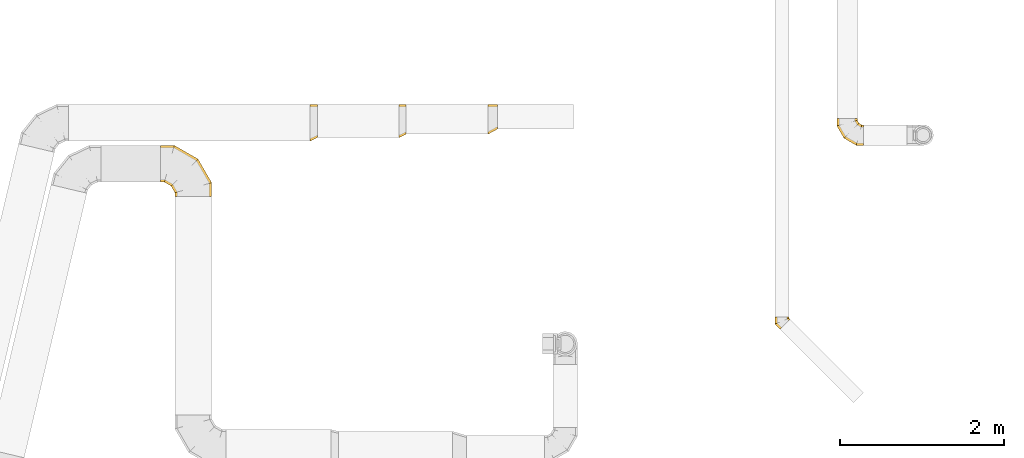
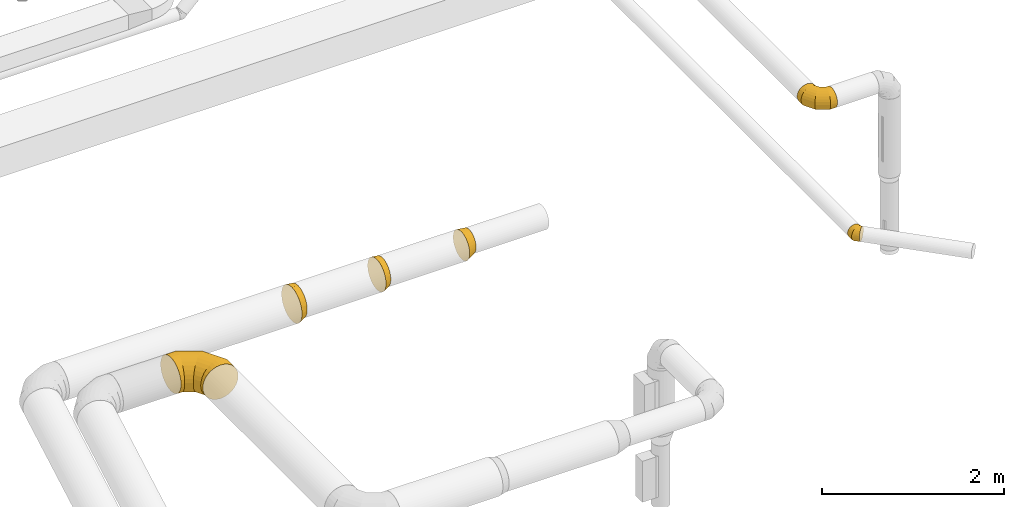
# One storey, part 21 of 97: 6 coverings.
"""IFC2X3 building model written with IfcOpenShell, lengths in millimetres."""

from ifc_helpers import new_model, entity, si_unit, converted_unit, derived_unit, direction, frame, origin, place, context, subcontext, project, spatial, faceted_brep, element, save


model = new_model("IFC2X3")

# Units and contexts
model_context = context("Model", 3, precision=0.01, world=origin(), true_north=direction((6.12303176911189e-17, 1.0)))
body_context = subcontext(model_context, "Body", "Model", "MODEL_VIEW")
ifc_project = project(units=[si_unit("LENGTHUNIT", "METRE", prefix="MILLI"), si_unit("AREAUNIT", "SQUARE_METRE"), si_unit("VOLUMEUNIT", "CUBIC_METRE"), converted_unit("PLANEANGLEUNIT", "DEGREE", entity("IfcRatioMeasure", 0.0174532925199433), si_unit("PLANEANGLEUNIT", "RADIAN"), dimensions=[0, 0, 0, 0, 0, 0, 0]), si_unit("MASSUNIT", "GRAM", prefix="KILO"), derived_unit("MASSDENSITYUNIT", [(si_unit("MASSUNIT", "GRAM", prefix="KILO"), 1), (si_unit("LENGTHUNIT", "METRE"), -3)]), derived_unit("MOMENTOFINERTIAUNIT", [(si_unit("LENGTHUNIT", "METRE"), 4)]), si_unit("TIMEUNIT", "SECOND"), si_unit("FREQUENCYUNIT", "HERTZ"), si_unit("THERMODYNAMICTEMPERATUREUNIT", "DEGREE_CELSIUS"), derived_unit("THERMALTRANSMITTANCEUNIT", [(si_unit("MASSUNIT", "GRAM", prefix="KILO"), 1), (si_unit("THERMODYNAMICTEMPERATUREUNIT", "KELVIN"), -1), (si_unit("TIMEUNIT", "SECOND"), -3)]), derived_unit("VOLUMETRICFLOWRATEUNIT", [(si_unit("LENGTHUNIT", "METRE"), 3), (si_unit("TIMEUNIT", "SECOND"), -1)]), derived_unit("MASSFLOWRATEUNIT", [(si_unit("MASSUNIT", "GRAM", prefix="KILO"), 1), (si_unit("TIMEUNIT", "SECOND"), -1)]), derived_unit("ROTATIONALFREQUENCYUNIT", [(si_unit("TIMEUNIT", "SECOND"), -1)]), si_unit("ELECTRICCURRENTUNIT", "AMPERE"), si_unit("ELECTRICVOLTAGEUNIT", "VOLT"), si_unit("POWERUNIT", "WATT"), si_unit("FORCEUNIT", "NEWTON", prefix="KILO"), si_unit("ILLUMINANCEUNIT", "LUX"), si_unit("LUMINOUSFLUXUNIT", "LUMEN"), si_unit("LUMINOUSINTENSITYUNIT", "CANDELA"), derived_unit("USERDEFINED", [(si_unit("MASSUNIT", "GRAM", prefix="KILO"), -1), (si_unit("LENGTHUNIT", "METRE"), -2), (si_unit("TIMEUNIT", "SECOND"), 3), (si_unit("LUMINOUSFLUXUNIT", "LUMEN"), 1)]), derived_unit("LINEARVELOCITYUNIT", [(si_unit("LENGTHUNIT", "METRE"), 1), (si_unit("TIMEUNIT", "SECOND"), -1)]), si_unit("PRESSUREUNIT", "PASCAL"), derived_unit("USERDEFINED", [(si_unit("LENGTHUNIT", "METRE"), -2), (si_unit("MASSUNIT", "GRAM", prefix="KILO"), 1), (si_unit("TIMEUNIT", "SECOND"), -2)]), derived_unit("LINEARFORCEUNIT", [(si_unit("MASSUNIT", "GRAM", prefix="KILO"), 1), (si_unit("LENGTHUNIT", "METRE"), 1), (si_unit("TIMEUNIT", "SECOND"), -2), (si_unit("LENGTHUNIT", "METRE"), -1)]), derived_unit("PLANARFORCEUNIT", [(si_unit("MASSUNIT", "GRAM", prefix="KILO"), 1), (si_unit("LENGTHUNIT", "METRE"), 1), (si_unit("TIMEUNIT", "SECOND"), -2), (si_unit("LENGTHUNIT", "METRE"), -2)])], contexts=[model_context])

# Site, building, storey
site_placement = place(None, origin())
site = spatial("IfcSite", under=ifc_project, at=site_placement, CompositionType="ELEMENT")
building_placement = place(site_placement, origin())
building = spatial("IfcBuilding", under=site, at=building_placement, CompositionType="ELEMENT")
storey_placement = place(building_placement, frame((0.0, 0.0, -4900.0)))
storey = spatial("IfcBuildingStorey", under=building, at=storey_placement, CompositionType="ELEMENT", Elevation=-4900.0)

# Coverings
covering_1_placement = place(storey_placement, frame((57567.98, 5372.13, 2723.4)))
element("IfcCovering", 1, at=covering_1_placement, inside=storey, PredefinedType="INSULATION", context=body_context, shape_type="Brep", body=[
    faceted_brep([(92.0, 248.6, 429.1), (92.0, 203.53, 424.02), (92.0, 160.73, 409.04), (92.0, 122.34, 384.92), (92.0, 90.27, 352.85), (92.0, 66.15, 314.46), (92.0, 51.17, 271.66), (92.0, 46.1, 226.6), (92.0, 51.17, 181.53), (92.0, 66.15, 138.73), (92.0, 90.27, 100.34), (92.0, 122.34, 68.27), (92.0, 160.73, 44.15), (92.0, 203.53, 29.17), (92.0, 248.6, 24.1), (92.0, 293.66, 29.17), (92.0, 336.46, 44.15), (92.0, 374.85, 68.27), (92.0, 406.92, 100.34), (92.0, 431.04, 138.73), (92.0, 446.02, 181.53), (92.0, 451.1, 226.6), (92.0, 446.02, 271.66), (92.0, 431.04, 314.46), (92.0, 406.92, 352.85), (92.0, 374.85, 384.92), (92.0, 336.46, 409.04), (92.0, 293.66, 424.02), (0.0, 276.66, 445.95), (0.0, 324.22, 429.31), (0.0, 366.88, 402.51), (0.0, 402.51, 366.88), (0.0, 429.31, 324.22), (0.0, 445.95, 276.66), (0.0, 451.6, 226.6), (0.0, 445.95, 176.53), (0.0, 429.31, 128.97), (0.0, 402.51, 86.31), (0.0, 366.88, 50.68), (0.0, 324.22, 23.88), (0.0, 276.66, 7.24), (0.0, 226.6, 1.6), (0.0, 176.53, 7.24), (0.0, 128.97, 23.88), (0.0, 86.31, 50.68), (0.0, 50.68, 86.31), (0.0, 23.88, 128.97), (0.0, 7.24, 176.53), (0.0, 1.6, 226.6), (0.0, 7.24, 276.66), (0.0, 23.88, 324.22), (0.0, 50.68, 366.88), (0.0, 86.31, 402.51), (0.0, 128.97, 429.31), (0.0, 176.53, 445.95), (0.0, 226.6, 451.6), (41.98, 21.9, 226.6), (46.0, 35.84, 156.0), (46.0, 56.61, 112.87), (46.0, 86.45, 75.45), (46.0, 167.0, 24.84), (41.98, 236.63, 11.86), (46.0, 123.87, 45.61), (43.57, 237.01, 12.25), (46.0, 308.19, 24.84), (46.0, 351.32, 45.61), (46.0, 388.74, 75.45), (43.57, 451.36, 226.6), (46.0, 439.35, 156.0), (46.0, 418.58, 112.87), (46.0, 439.35, 297.19), (46.0, 418.58, 340.32), (46.0, 388.74, 377.74), (43.57, 237.01, 440.94), (46.0, 308.19, 428.35), (46.0, 351.32, 407.58), (41.98, 236.63, 441.33), (46.0, 167.0, 428.35), (46.0, 123.87, 407.58), (46.0, 86.45, 377.74), (46.0, 35.84, 297.19), (46.0, 56.61, 340.32)], [[[0, 1, 2, 3, 4, 5, 6, 7, 8, 9, 10, 11, 12, 13, 14, 15, 16, 17, 18, 19, 20, 21, 22, 23, 24, 25, 26, 27]], [[28, 29, 30, 31, 32, 33, 34, 35, 36, 37, 38, 39, 40, 41, 42, 43, 44, 45, 46, 47, 48, 49, 50, 51, 52, 53, 54, 55]], [[56, 47, 57]], [[9, 58, 10]], [[46, 45, 58]], [[56, 8, 7]], [[56, 48, 47]], [[8, 57, 9]], [[47, 46, 57]], [[58, 57, 46]], [[59, 58, 45]], [[57, 58, 9]], [[57, 8, 56]], [[58, 59, 10]], [[59, 11, 10]], [[60, 42, 61]], [[62, 44, 43]], [[44, 59, 45]], [[60, 43, 42]], [[11, 62, 12]], [[13, 61, 63, 14]], [[42, 41, 61]], [[60, 62, 43]], [[62, 11, 59]], [[60, 12, 62]], [[61, 13, 60]], [[59, 44, 62]], [[12, 60, 13]], [[63, 40, 64]], [[16, 65, 17]], [[39, 38, 65]], [[63, 15, 14]], [[40, 63, 61, 41]], [[15, 64, 16]], [[40, 39, 64]], [[65, 64, 39]], [[66, 65, 38]], [[64, 65, 16]], [[15, 63, 64]], [[65, 66, 17]], [[66, 18, 17]], [[67, 20, 68]], [[69, 37, 36]], [[37, 66, 38]], [[68, 36, 35]], [[19, 68, 20]], [[18, 69, 19]], [[67, 21, 20]], [[35, 34, 67]], [[68, 69, 36]], [[69, 18, 66]], [[68, 19, 69]], [[68, 35, 67]], [[66, 37, 69]], [[67, 33, 70]], [[23, 71, 24]], [[32, 31, 71]], [[67, 22, 21]], [[67, 34, 33]], [[22, 70, 23]], [[33, 32, 70]], [[71, 70, 32]], [[72, 71, 31]], [[70, 71, 23]], [[22, 67, 70]], [[71, 72, 24]], [[72, 25, 24]], [[73, 27, 74]], [[75, 30, 29]], [[30, 72, 31]], [[74, 29, 28]], [[26, 74, 27]], [[25, 75, 26]], [[73, 0, 27]], [[28, 55, 76, 73]], [[74, 75, 29]], [[75, 25, 72]], [[74, 26, 75]], [[74, 28, 73]], [[72, 30, 75]], [[76, 54, 77]], [[2, 78, 3]], [[53, 52, 78]], [[1, 0, 73, 76]], [[76, 55, 54]], [[1, 77, 2]], [[54, 53, 77]], [[78, 77, 53]], [[79, 78, 52]], [[77, 78, 2]], [[77, 1, 76]], [[78, 79, 3]], [[79, 4, 3]], [[80, 49, 56]], [[81, 51, 50]], [[51, 79, 52]], [[80, 50, 49]], [[4, 81, 5]], [[56, 7, 6]], [[49, 48, 56]], [[80, 81, 50]], [[81, 4, 79]], [[80, 5, 81]], [[56, 6, 80]], [[79, 51, 81]], [[5, 80, 6]]]),
])
covering_2_placement = place(storey_placement, frame((58659.62, 5416.63, 2745.9)))
element("IfcCovering", 2, at=covering_2_placement, inside=storey, PredefinedType="INSULATION", context=body_context, shape_type="Brep", body=[
    faceted_brep([(85.0, 177.36, 380.38), (85.0, 133.35, 362.14), (85.0, 95.55, 333.14), (85.0, 66.55, 295.35), (85.0, 48.32, 251.33), (85.0, 42.1, 204.1), (85.0, 48.32, 156.86), (85.0, 66.55, 112.85), (85.0, 95.55, 75.05), (85.0, 133.35, 46.05), (85.0, 177.36, 27.81), (85.0, 224.6, 21.6), (85.0, 271.83, 27.81), (85.0, 315.85, 46.05), (85.0, 353.65, 75.05), (85.0, 382.65, 112.85), (85.0, 400.88, 156.86), (85.0, 407.1, 204.1), (85.0, 400.88, 251.33), (85.0, 382.65, 295.35), (85.0, 353.65, 333.14), (85.0, 315.85, 362.14), (85.0, 271.83, 380.38), (85.0, 224.6, 386.6), (0.0, 249.16, 401.52), (0.0, 291.96, 386.54), (0.0, 330.35, 362.42), (0.0, 362.42, 330.35), (0.0, 386.54, 291.96), (0.0, 401.52, 249.16), (0.0, 406.6, 204.1), (0.0, 401.52, 159.03), (0.0, 386.54, 116.23), (0.0, 362.42, 77.84), (0.0, 330.35, 45.77), (0.0, 291.96, 21.65), (0.0, 249.16, 6.67), (0.0, 204.1, 1.6), (0.0, 159.03, 6.67), (0.0, 116.23, 21.65), (0.0, 77.84, 45.77), (0.0, 45.77, 77.84), (0.0, 21.65, 116.23), (0.0, 6.67, 159.03), (0.0, 1.6, 204.1), (0.0, 6.67, 249.16), (0.0, 21.65, 291.96), (0.0, 45.77, 330.35), (0.0, 77.84, 362.42), (0.0, 116.23, 386.54), (0.0, 159.03, 401.52), (0.0, 204.1, 406.6), (40.52, 31.73, 140.36), (39.34, 49.96, 101.28), (38.34, 213.34, 10.62), (40.52, 150.14, 21.96), (38.34, 19.87, 204.1), (40.14, 74.72, 70.18), (39.34, 110.77, 40.47), (39.75, 213.68, 10.95), (40.52, 277.6, 21.96), (39.34, 316.4, 40.47), (39.75, 406.83, 204.1), (40.52, 396.01, 140.36), (40.14, 347.69, 65.03), (39.34, 377.21, 101.28), (40.52, 396.01, 267.83), (39.34, 377.21, 306.91), (39.75, 213.68, 397.24), (40.52, 277.6, 386.23), (38.34, 213.34, 397.57), (40.14, 352.84, 338.01), (39.34, 316.4, 367.72), (40.52, 150.14, 386.23), (39.34, 110.77, 367.72), (40.52, 31.73, 267.83), (40.14, 79.87, 343.16), (39.34, 49.96, 306.91)], [[[0, 1, 2, 3, 4, 5, 6, 7, 8, 9, 10, 11, 12, 13, 14, 15, 16, 17, 18, 19, 20, 21, 22, 23]], [[24, 25, 26, 27, 28, 29, 30, 31, 32, 33, 34, 35, 36, 37, 38, 39, 40, 41, 42, 43, 44, 45, 46, 47, 48, 49, 50, 51]], [[52, 42, 53]], [[54, 55, 38]], [[56, 6, 5]], [[56, 43, 52]], [[56, 44, 43]], [[38, 37, 54]], [[7, 6, 52]], [[53, 42, 41]], [[43, 42, 52]], [[56, 52, 6]], [[8, 7, 53]], [[57, 40, 58]], [[58, 40, 39]], [[53, 41, 57]], [[55, 39, 38]], [[41, 40, 57]], [[10, 54, 59, 11]], [[9, 55, 10]], [[58, 8, 57]], [[58, 9, 8]], [[55, 9, 58]], [[55, 54, 10]], [[52, 53, 7]], [[8, 53, 57]], [[55, 58, 39]], [[60, 35, 61]], [[62, 63, 31]], [[59, 12, 11]], [[59, 36, 60]], [[36, 59, 54, 37]], [[31, 30, 62]], [[13, 12, 60]], [[61, 35, 34]], [[36, 35, 60]], [[59, 60, 12]], [[14, 13, 61]], [[64, 33, 65]], [[65, 33, 32]], [[61, 34, 64]], [[63, 32, 31]], [[34, 33, 64]], [[62, 17, 16]], [[15, 63, 16]], [[65, 14, 64]], [[65, 15, 14]], [[63, 15, 65]], [[63, 62, 16]], [[60, 61, 13]], [[14, 61, 64]], [[63, 65, 32]], [[66, 28, 67]], [[68, 69, 24]], [[62, 18, 17]], [[62, 29, 66]], [[62, 30, 29]], [[24, 51, 70, 68]], [[19, 18, 66]], [[67, 28, 27]], [[29, 28, 66]], [[62, 66, 18]], [[20, 19, 67]], [[71, 26, 72]], [[72, 26, 25]], [[67, 27, 71]], [[69, 25, 24]], [[27, 26, 71]], [[68, 23, 22]], [[21, 69, 22]], [[72, 20, 71]], [[72, 21, 20]], [[69, 21, 72]], [[69, 68, 22]], [[66, 67, 19]], [[20, 67, 71]], [[69, 72, 25]], [[73, 49, 74]], [[56, 75, 45]], [[0, 23, 68, 70]], [[70, 50, 73]], [[70, 51, 50]], [[45, 44, 56]], [[1, 0, 73]], [[74, 49, 48]], [[50, 49, 73]], [[70, 73, 0]], [[2, 1, 74]], [[76, 47, 77]], [[77, 47, 46]], [[74, 48, 76]], [[75, 46, 45]], [[48, 47, 76]], [[56, 5, 4]], [[3, 75, 4]], [[77, 2, 76]], [[77, 3, 2]], [[75, 3, 77]], [[75, 56, 4]], [[73, 74, 1]], [[2, 74, 76]], [[75, 77, 46]]]),
])
covering_3_placement = place(storey_placement, frame((59744.39, 5457.13, 2765.9)))
element("IfcCovering", 3, at=covering_3_placement, inside=storey, PredefinedType="INSULATION", context=body_context, shape_type="Brep", body=[
    faceted_brep([(119.0, 216.1, 334.1), (119.0, 177.27, 328.98), (119.0, 141.1, 314.0), (119.0, 110.03, 290.16), (119.0, 86.19, 259.1), (119.0, 71.21, 222.92), (119.0, 66.1, 184.1), (119.0, 71.21, 145.27), (119.0, 86.19, 109.1), (119.0, 110.03, 78.03), (119.0, 141.1, 54.19), (119.0, 177.27, 39.21), (119.0, 216.1, 34.1), (119.0, 254.92, 39.21), (119.0, 291.1, 54.19), (119.0, 322.16, 78.03), (119.0, 346.0, 109.1), (119.0, 360.98, 145.27), (119.0, 366.1, 184.1), (119.0, 360.98, 222.92), (119.0, 346.0, 259.1), (119.0, 322.16, 290.16), (119.0, 291.1, 314.0), (119.0, 254.92, 328.98), (0.0, 231.33, 360.38), (0.0, 275.35, 342.14), (0.0, 313.14, 313.14), (0.0, 342.14, 275.35), (0.0, 360.38, 231.33), (0.0, 366.6, 184.1), (0.0, 360.38, 136.86), (0.0, 342.14, 92.85), (0.0, 313.14, 55.05), (0.0, 275.35, 26.05), (0.0, 231.33, 7.81), (0.0, 184.1, 1.6), (0.0, 136.86, 7.81), (0.0, 92.85, 26.05), (0.0, 55.05, 55.05), (0.0, 26.05, 92.85), (0.0, 7.81, 136.86), (0.0, 1.6, 184.1), (0.0, 7.81, 231.33), (0.0, 26.05, 275.35), (0.0, 55.05, 313.14), (0.0, 92.85, 342.14), (0.0, 136.86, 360.38), (0.0, 184.1, 366.6), (59.5, 46.5, 120.47), (35.65, 20.92, 184.1), (58.29, 36.17, 152.73), (59.5, 68.2, 82.89), (83.35, 46.77, 184.1), (59.5, 98.89, 52.2), (59.5, 136.47, 30.5), (60.71, 169.18, 21.14), (83.35, 206.51, 24.36), (75.39, 204.37, 22.19), (59.5, 263.72, 30.5), (57.73, 231.46, 20.43), (59.5, 301.3, 52.2), (59.5, 331.99, 82.89), (59.5, 353.69, 120.47), (61.27, 363.29, 152.44), (43.61, 366.41, 184.1), (75.39, 366.28, 184.1), (59.5, 353.69, 247.72), (57.73, 363.28, 215.94), (59.5, 331.99, 285.3), (59.5, 301.3, 315.99), (59.5, 263.72, 337.69), (61.27, 232.23, 346.81), (35.65, 193.68, 356.86), (43.61, 195.82, 354.69), (59.5, 136.47, 337.69), (58.29, 168.4, 347.7), (59.5, 98.89, 315.99), (59.5, 68.2, 285.3), (59.5, 46.5, 247.72), (60.71, 37.47, 215.34)], [[[0, 1, 2, 3, 4, 5, 6, 7, 8, 9, 10, 11, 12, 13, 14, 15, 16, 17, 18, 19, 20, 21, 22, 23]], [[24, 25, 26, 27, 28, 29, 30, 31, 32, 33, 34, 35, 36, 37, 38, 39, 40, 41, 42, 43, 44, 45, 46, 47]], [[8, 7, 48]], [[41, 40, 49]], [[39, 48, 40]], [[40, 50, 49]], [[51, 48, 39]], [[50, 40, 48]], [[39, 38, 51]], [[50, 6, 52, 49]], [[8, 48, 51]], [[53, 51, 38]], [[51, 9, 8]], [[10, 54, 11]], [[54, 37, 36]], [[54, 36, 55]], [[6, 50, 7]], [[56, 12, 11]], [[9, 51, 53]], [[53, 10, 9]], [[54, 53, 37]], [[54, 10, 53]], [[38, 37, 53]], [[55, 35, 57, 56]], [[48, 7, 50]], [[55, 56, 11]], [[35, 55, 36]], [[11, 54, 55]], [[14, 13, 58]], [[34, 59, 35]], [[33, 58, 34]], [[13, 12, 59]], [[60, 58, 33]], [[58, 59, 34]], [[33, 32, 60]], [[59, 12, 56, 57, 35]], [[14, 58, 60]], [[61, 60, 32]], [[60, 15, 14]], [[16, 62, 17]], [[62, 31, 30]], [[30, 63, 62]], [[18, 17, 63]], [[61, 16, 15]], [[62, 61, 31]], [[31, 61, 32]], [[62, 16, 61]], [[60, 61, 15]], [[29, 64, 65, 18, 63]], [[13, 59, 58]], [[29, 63, 30]], [[63, 17, 62]], [[20, 19, 66]], [[28, 67, 29]], [[27, 66, 28]], [[19, 18, 67]], [[68, 66, 27]], [[66, 67, 28]], [[27, 26, 68]], [[18, 65, 64, 29, 67]], [[20, 66, 68]], [[69, 68, 26]], [[68, 21, 20]], [[22, 70, 23]], [[70, 25, 24]], [[24, 71, 70]], [[0, 23, 71]], [[69, 22, 21]], [[70, 69, 25]], [[25, 69, 26]], [[70, 22, 69]], [[68, 69, 21]], [[71, 47, 72, 73, 0]], [[19, 67, 66]], [[47, 71, 24]], [[71, 23, 70]], [[2, 1, 74]], [[47, 46, 72]], [[45, 74, 46]], [[46, 75, 72]], [[76, 74, 45]], [[75, 46, 74]], [[45, 44, 76]], [[75, 0, 73, 72]], [[2, 74, 76]], [[77, 76, 44]], [[76, 3, 2]], [[4, 78, 5]], [[78, 43, 42]], [[78, 42, 79]], [[0, 75, 1]], [[52, 6, 5]], [[3, 76, 77]], [[77, 4, 3]], [[78, 77, 43]], [[78, 4, 77]], [[44, 43, 77]], [[79, 41, 49, 52]], [[74, 1, 75]], [[79, 52, 5]], [[41, 79, 42]], [[5, 78, 79]]]),
])
covering_4_placement = place(storey_placement, frame((55743.98, 4698.32, 2723.4)))
element("IfcCovering", 4, at=covering_4_placement, inside=storey, PredefinedType="INSULATION", context=body_context, shape_type="Brep", body=[
    faceted_brep([(0.0, 400.0, 451.6), (0.0, 450.07, 445.95), (0.0, 497.62, 429.31), (0.0, 540.29, 402.51), (0.0, 575.91, 366.88), (0.0, 602.72, 324.22), (0.0, 619.36, 276.66), (0.0, 625.0, 226.6), (0.0, 619.36, 176.53), (0.0, 602.72, 128.97), (0.0, 575.91, 86.31), (0.0, 540.29, 50.68), (0.0, 497.62, 23.88), (0.0, 450.07, 7.24), (0.0, 400.0, 1.6), (0.0, 349.93, 7.24), (0.0, 302.38, 23.88), (0.0, 259.71, 50.68), (0.0, 224.09, 86.31), (0.0, 197.28, 128.97), (0.0, 180.64, 176.53), (0.0, 175.0, 226.6), (0.0, 180.64, 276.66), (0.0, 197.28, 324.22), (0.0, 224.09, 366.88), (0.0, 259.71, 402.51), (0.0, 302.38, 429.31), (0.0, 349.93, 445.95), (575.91, 0.0, 86.31), (602.72, 0.0, 128.97), (619.36, 0.0, 176.53), (625.0, 0.0, 226.6), (619.36, 0.0, 276.66), (602.72, 0.0, 324.22), (575.91, 0.0, 366.88), (540.29, 0.0, 402.51), (497.62, 0.0, 429.31), (450.07, 0.0, 445.95), (400.0, 0.0, 451.6), (349.93, 0.0, 445.95), (302.38, 0.0, 429.31), (259.71, 0.0, 402.51), (224.09, 0.0, 366.88), (197.28, 0.0, 324.22), (180.64, 0.0, 276.66), (175.0, 0.0, 226.6), (180.64, 0.0, 176.53), (197.28, 0.0, 128.97), (224.09, 0.0, 86.31), (259.71, 0.0, 50.68), (302.38, 0.0, 23.88), (349.93, 0.0, 7.24), (400.0, 0.0, 1.6), (450.07, 0.0, 7.24), (497.62, 0.0, 23.88), (540.29, 0.0, 50.68), (625.0, 167.47, 226.6), (619.36, 165.96, 276.66), (602.72, 161.5, 324.22), (575.91, 154.32, 366.88), (540.29, 144.77, 402.51), (497.62, 133.34, 429.31), (450.07, 120.6, 445.95), (400.0, 107.18, 451.6), (349.93, 93.76, 445.95), (302.38, 81.02, 429.31), (259.71, 69.59, 402.51), (224.09, 60.04, 366.88), (197.28, 52.86, 324.22), (180.64, 48.4, 276.66), (175.0, 46.89, 226.6), (180.64, 48.4, 176.53), (197.28, 52.86, 128.97), (224.09, 60.04, 86.31), (259.71, 69.59, 50.68), (302.38, 81.02, 23.88), (349.93, 93.76, 7.24), (400.0, 107.18, 1.6), (450.07, 120.6, 7.24), (497.62, 133.34, 23.88), (540.29, 144.77, 50.68), (575.91, 154.32, 86.31), (602.72, 161.5, 128.97), (619.36, 165.96, 176.53), (457.53, 457.53, 226.6), (453.4, 453.4, 276.66), (441.22, 441.22, 324.22), (421.6, 421.6, 366.88), (395.52, 395.52, 402.51), (364.29, 364.29, 429.31), (329.47, 329.47, 445.95), (292.82, 292.82, 451.6), (256.17, 256.17, 445.95), (221.35, 221.35, 429.31), (190.12, 190.12, 402.51), (164.04, 164.04, 366.88), (144.42, 144.42, 324.22), (132.24, 132.24, 276.66), (128.11, 128.11, 226.6), (132.24, 132.24, 176.53), (144.42, 144.42, 128.97), (164.04, 164.04, 86.31), (190.12, 190.12, 50.68), (221.35, 221.35, 23.88), (256.17, 256.17, 7.24), (292.82, 292.82, 1.6), (329.47, 329.47, 7.24), (364.29, 364.29, 23.88), (395.52, 395.52, 50.68), (421.6, 421.6, 86.31), (441.22, 441.22, 128.97), (453.4, 453.4, 176.53), (167.47, 625.0, 226.6), (165.96, 619.36, 276.66), (161.5, 602.72, 324.22), (154.32, 575.91, 366.88), (144.77, 540.29, 402.51), (133.34, 497.62, 429.31), (120.6, 450.07, 445.95), (107.18, 400.0, 451.6), (93.76, 349.93, 445.95), (81.02, 302.38, 429.31), (69.59, 259.71, 402.51), (60.04, 224.09, 366.88), (52.86, 197.28, 324.22), (48.4, 180.64, 276.66), (46.89, 175.0, 226.6), (48.4, 180.64, 176.53), (52.86, 197.28, 128.97), (60.04, 224.09, 86.31), (69.59, 259.71, 50.68), (81.02, 302.38, 23.88), (93.76, 349.93, 7.24), (107.18, 400.0, 1.6), (120.6, 450.07, 7.24), (133.34, 497.62, 23.88), (144.77, 540.29, 50.68), (154.32, 575.91, 86.31), (161.5, 602.72, 128.97), (165.96, 619.36, 176.53)], [[[0, 1, 2, 3, 4, 5, 6, 7, 8, 9, 10, 11, 12, 13, 14, 15, 16, 17, 18, 19, 20, 21, 22, 23, 24, 25, 26, 27]], [[28, 29, 30, 31, 32, 33, 34, 35, 36, 37, 38, 39, 40, 41, 42, 43, 44, 45, 46, 47, 48, 49, 50, 51, 52, 53, 54, 55]], [[31, 56, 57, 32]], [[32, 57, 58, 33]], [[33, 58, 59, 34]], [[59, 60, 35, 34]], [[35, 60, 61, 36]], [[36, 61, 62, 37]], [[37, 62, 63, 38]], [[63, 64, 39, 38]], [[65, 66, 41, 40]], [[64, 65, 40, 39]], [[66, 67, 42, 41]], [[67, 68, 43, 42]], [[69, 70, 45, 44]], [[68, 69, 44, 43]], [[70, 71, 46, 45]], [[72, 73, 48, 47]], [[71, 72, 47, 46]], [[73, 74, 49, 48]], [[74, 75, 50, 49]], [[76, 77, 52, 51]], [[75, 76, 51, 50]], [[53, 52, 77, 78]], [[78, 79, 54, 53]], [[80, 55, 54, 79]], [[80, 81, 28, 55]], [[29, 28, 81, 82]], [[82, 83, 30, 29]], [[56, 31, 30, 83]], [[57, 56, 84, 85]], [[57, 85, 86, 58]], [[59, 58, 86, 87]], [[87, 88, 60, 59]], [[61, 60, 88, 89]], [[62, 61, 89, 90]], [[63, 62, 90, 91]], [[91, 92, 64, 63]], [[93, 94, 66, 65]], [[92, 93, 65, 64]], [[94, 95, 67, 66]], [[95, 96, 68, 67]], [[97, 98, 70, 69]], [[96, 97, 69, 68]], [[98, 99, 71, 70]], [[100, 101, 73, 72]], [[99, 100, 72, 71]], [[101, 102, 74, 73]], [[102, 103, 75, 74]], [[104, 105, 77, 76]], [[103, 104, 76, 75]], [[78, 77, 105, 106]], [[106, 107, 79, 78]], [[108, 80, 79, 107]], [[108, 109, 81, 80]], [[82, 81, 109, 110]], [[110, 111, 83, 82]], [[84, 56, 83, 111]], [[85, 84, 112, 113]], [[85, 113, 114, 86]], [[87, 86, 114, 115]], [[115, 116, 88, 87]], [[89, 88, 116, 117]], [[90, 89, 117, 118]], [[91, 90, 118, 119]], [[119, 120, 92, 91]], [[121, 122, 94, 93]], [[120, 121, 93, 92]], [[122, 123, 95, 94]], [[123, 124, 96, 95]], [[125, 126, 98, 97]], [[124, 125, 97, 96]], [[126, 127, 99, 98]], [[128, 129, 101, 100]], [[127, 128, 100, 99]], [[129, 130, 102, 101]], [[130, 131, 103, 102]], [[132, 133, 105, 104]], [[131, 132, 104, 103]], [[106, 105, 133, 134]], [[134, 135, 107, 106]], [[136, 108, 107, 135]], [[136, 137, 109, 108]], [[110, 109, 137, 138]], [[138, 139, 111, 110]], [[112, 84, 111, 139]], [[113, 112, 7, 6]], [[5, 4, 115, 114]], [[114, 113, 6, 5]], [[4, 3, 116, 115]], [[117, 116, 3, 2]], [[118, 117, 2, 1]], [[119, 118, 1, 0]], [[120, 119, 0, 27]], [[26, 25, 122, 121]], [[121, 120, 27, 26]], [[25, 24, 123, 122]], [[124, 123, 24, 23]], [[125, 124, 23, 22]], [[126, 125, 22, 21]], [[21, 20, 127, 126]], [[20, 19, 128, 127]], [[128, 19, 18, 129]], [[18, 17, 130, 129]], [[130, 17, 16, 131]], [[131, 16, 15, 132]], [[132, 15, 14, 133]], [[133, 14, 13, 134]], [[134, 13, 12, 135]], [[135, 12, 11, 136]], [[11, 10, 137, 136]], [[137, 10, 9, 138]], [[138, 9, 8, 139]], [[139, 8, 7, 112]]]),
])
covering_5_placement = place(storey_placement, frame((63249.01, 3074.62, 3260.9)))
element("IfcCovering", 5, at=covering_5_placement, inside=storey, PredefinedType="INSULATION", context=body_context, shape_type="Brep", body=[
    faceted_brep([(175.76, 113.52, 37.66), (180.16, 117.92, 49.86), (184.55, 122.31, 62.06), (186.06, 123.82, 75.58), (187.58, 125.34, 89.1), (186.06, 123.82, 102.61), (184.55, 122.31, 116.13), (180.16, 117.92, 128.33), (175.76, 113.52, 140.53), (162.07, 99.83, 159.88), (144.83, 82.59, 172.31), (125.71, 63.47, 176.6), (106.59, 44.35, 172.31), (89.34, 27.1, 159.88), (75.65, 13.41, 140.53), (66.86, 4.62, 116.13), (63.84, 1.6, 89.1), (66.86, 4.62, 62.06), (75.65, 13.41, 37.66), (89.34, 27.1, 18.31), (106.59, 44.35, 5.88), (125.71, 63.47, 1.6), (144.83, 82.59, 5.88), (162.07, 99.83, 18.31), (13.32, 151.86, 45.35), (4.58, 151.86, 66.45), (1.6, 151.86, 89.1), (4.58, 151.86, 111.74), (13.32, 151.86, 132.85), (27.22, 151.86, 150.97), (45.35, 151.86, 164.87), (66.45, 151.86, 173.61), (89.1, 151.86, 176.6), (111.74, 151.86, 173.61), (132.85, 151.86, 164.87), (150.97, 151.86, 150.97), (164.87, 151.86, 132.85), (173.61, 151.86, 111.74), (176.6, 151.86, 89.1), (173.61, 151.86, 66.45), (164.87, 151.86, 45.35), (150.97, 151.86, 27.22), (132.85, 151.86, 13.32), (111.74, 151.86, 4.58), (89.1, 151.86, 1.6), (66.45, 151.86, 4.58), (45.35, 151.86, 13.32), (27.22, 151.86, 27.22), (1.6, 63.84, 89.1), (4.58, 65.07, 111.74), (13.32, 68.69, 132.85), (27.22, 74.45, 150.97), (45.35, 81.96, 164.87), (66.45, 90.7, 173.61), (89.1, 100.08, 176.6), (111.74, 109.46, 173.61), (132.85, 118.2, 164.87), (150.97, 125.71, 150.97), (164.87, 131.47, 132.85), (173.61, 135.09, 111.74), (176.6, 136.32, 89.1), (175.1, 135.7, 100.42), (173.61, 135.09, 66.45), (164.87, 131.47, 45.35), (175.1, 135.7, 77.77), (150.97, 125.71, 27.22), (111.74, 109.46, 4.58), (89.1, 100.08, 1.6), (132.85, 118.2, 13.32), (66.45, 90.7, 4.58), (45.35, 81.96, 13.32), (27.22, 74.45, 27.22), (13.32, 68.69, 45.35), (4.58, 65.07, 66.45)], [[[0, 1, 2, 3, 4, 5, 6, 7, 8, 9, 10, 11, 12, 13, 14, 15, 16, 17, 18, 19, 20, 21, 22, 23]], [[24, 25, 26, 27, 28, 29, 30, 31, 32, 33, 34, 35, 36, 37, 38, 39, 40, 41, 42, 43, 44, 45, 46, 47]], [[26, 48, 49, 27]], [[27, 49, 50, 28]], [[51, 29, 28, 50]], [[29, 51, 52, 30]], [[30, 52, 53, 31]], [[54, 32, 31, 53]], [[55, 56, 34, 33]], [[54, 55, 33, 32]], [[57, 35, 34, 56]], [[58, 59, 37, 36]], [[58, 36, 35, 57]], [[60, 38, 37, 59, 61]], [[62, 63, 40, 39]], [[39, 38, 60, 64, 62]], [[41, 40, 63, 65]], [[66, 67, 44, 43]], [[68, 66, 43, 42]], [[65, 68, 42, 41]], [[45, 44, 67, 69]], [[46, 45, 69, 70]], [[70, 71, 47, 46]], [[25, 24, 72, 73]], [[26, 25, 73, 48]], [[71, 72, 24, 47]], [[15, 14, 50]], [[16, 15, 49]], [[16, 49, 48]], [[49, 15, 50]], [[14, 51, 50]], [[52, 13, 12]], [[53, 12, 11]], [[51, 13, 52]], [[52, 12, 53]], [[11, 54, 53]], [[13, 51, 14]], [[55, 11, 10]], [[56, 10, 9]], [[55, 54, 11]], [[56, 55, 10]], [[9, 57, 56]], [[4, 61, 5]], [[60, 61, 4]], [[6, 59, 7]], [[59, 6, 5]], [[58, 57, 8]], [[58, 8, 7]], [[59, 5, 61]], [[7, 59, 58]], [[8, 57, 9]], [[62, 3, 2]], [[63, 1, 0]], [[4, 64, 60]], [[4, 3, 64]], [[62, 2, 1]], [[62, 1, 63]], [[0, 65, 63]], [[3, 62, 64]], [[22, 21, 66]], [[23, 22, 68]], [[68, 65, 23]], [[67, 66, 21]], [[68, 22, 66]], [[23, 65, 0]], [[69, 21, 20]], [[70, 20, 19]], [[21, 69, 67]], [[69, 20, 70]], [[19, 71, 70]], [[72, 18, 17]], [[73, 17, 16]], [[71, 18, 72]], [[73, 72, 17]], [[48, 73, 16]], [[18, 71, 19]]]),
])
covering_6_placement = place(storey_placement, frame((64007.19, 5321.85, 3323.4)))
element("IfcCovering", 6, at=covering_6_placement, inside=storey, PredefinedType="INSULATION", context=body_context, shape_type="Brep", body=[
    faceted_brep([(326.6, 165.22, 245.48), (326.6, 126.6, 251.6), (326.6, 87.97, 245.48), (326.6, 53.12, 227.72), (326.6, 25.47, 200.07), (326.6, 7.71, 165.22), (326.6, 1.6, 126.6), (326.6, 7.71, 87.97), (326.6, 25.47, 53.12), (326.6, 53.12, 25.47), (326.6, 87.97, 7.71), (326.6, 126.6, 1.6), (326.6, 165.22, 7.71), (326.6, 200.07, 25.47), (326.6, 227.72, 53.12), (326.6, 245.48, 87.97), (326.6, 251.6, 126.6), (326.6, 245.48, 165.22), (326.6, 227.72, 200.07), (326.6, 200.07, 227.72), (18.34, 326.6, 64.1), (5.85, 326.6, 94.24), (1.6, 326.6, 126.6), (5.85, 326.6, 158.95), (18.34, 326.6, 189.1), (38.21, 326.6, 214.98), (64.1, 326.6, 234.85), (94.24, 326.6, 247.34), (126.6, 326.6, 251.6), (158.95, 326.6, 247.34), (189.1, 326.6, 234.85), (214.98, 326.6, 214.98), (234.85, 326.6, 189.1), (247.34, 326.6, 158.95), (251.6, 326.6, 126.6), (247.34, 326.6, 94.24), (234.85, 326.6, 64.1), (214.98, 326.6, 38.21), (189.1, 326.6, 18.34), (158.95, 326.6, 5.85), (126.6, 326.6, 1.6), (94.24, 326.6, 5.85), (64.1, 326.6, 18.34), (38.21, 326.6, 38.21), (1.6, 239.51, 126.6), (5.85, 240.65, 158.95), (18.34, 244.0, 189.1), (38.21, 249.32, 214.98), (64.1, 256.26, 234.85), (94.24, 264.34, 247.34), (126.6, 273.01, 251.6), (158.95, 281.67, 247.34), (189.1, 289.75, 234.85), (214.98, 296.69, 214.98), (234.85, 302.01, 189.1), (247.34, 305.36, 158.95), (251.6, 306.5, 126.6), (247.34, 305.36, 94.24), (234.85, 302.01, 64.1), (214.98, 296.69, 38.21), (158.95, 281.67, 5.85), (126.6, 273.01, 1.6), (189.1, 289.75, 18.34), (94.24, 264.34, 5.85), (64.1, 256.26, 18.34), (38.21, 249.32, 38.21), (18.34, 244.0, 64.1), (5.85, 240.65, 94.24), (88.68, 88.68, 126.6), (91.8, 91.8, 158.95), (100.94, 100.94, 189.1), (115.48, 115.48, 214.98), (134.43, 134.43, 234.85), (156.5, 156.5, 247.34), (180.19, 180.19, 251.6), (203.87, 203.87, 247.34), (225.94, 225.94, 234.85), (244.89, 244.89, 214.98), (259.43, 259.43, 189.1), (268.57, 268.57, 158.95), (271.69, 271.69, 126.6), (268.57, 268.57, 94.24), (259.43, 259.43, 64.1), (244.89, 244.89, 38.21), (203.87, 203.87, 5.85), (180.19, 180.19, 1.6), (225.94, 225.94, 18.34), (156.5, 156.5, 5.85), (134.43, 134.43, 18.34), (115.48, 115.48, 38.21), (100.94, 100.94, 64.1), (91.8, 91.8, 94.24), (239.51, 1.6, 126.6), (240.65, 5.85, 158.95), (244.0, 18.34, 189.1), (249.32, 38.21, 214.98), (256.26, 64.1, 234.85), (264.34, 94.24, 247.34), (273.01, 126.6, 251.6), (281.67, 158.95, 247.34), (289.75, 189.1, 234.85), (296.69, 214.98, 214.98), (302.01, 234.85, 189.1), (305.36, 247.34, 158.95), (306.5, 251.6, 126.6), (305.36, 247.34, 94.24), (302.01, 234.85, 64.1), (296.69, 214.98, 38.21), (281.67, 158.95, 5.85), (273.01, 126.6, 1.6), (289.75, 189.1, 18.34), (264.34, 94.24, 5.85), (256.26, 64.1, 18.34), (249.32, 38.21, 38.21), (244.0, 18.34, 64.1), (240.65, 5.85, 94.24)], [[[0, 1, 2, 3, 4, 5, 6, 7, 8, 9, 10, 11, 12, 13, 14, 15, 16, 17, 18, 19]], [[20, 21, 22, 23, 24, 25, 26, 27, 28, 29, 30, 31, 32, 33, 34, 35, 36, 37, 38, 39, 40, 41, 42, 43]], [[22, 44, 45, 23]], [[23, 45, 46, 24]], [[47, 25, 24, 46]], [[25, 47, 48, 26]], [[26, 48, 49, 27]], [[50, 28, 27, 49]], [[51, 52, 30, 29]], [[50, 51, 29, 28]], [[53, 31, 30, 52]], [[54, 55, 33, 32]], [[54, 32, 31, 53]], [[56, 34, 33, 55]], [[57, 58, 36, 35]], [[56, 57, 35, 34]], [[37, 36, 58, 59]], [[60, 61, 40, 39]], [[62, 60, 39, 38]], [[59, 62, 38, 37]], [[41, 40, 61, 63]], [[42, 41, 63, 64]], [[64, 65, 43, 42]], [[21, 20, 66, 67]], [[22, 21, 67, 44]], [[65, 66, 20, 43]], [[45, 44, 68, 69]], [[46, 45, 69, 70]], [[70, 71, 47, 46]], [[48, 47, 71, 72]], [[49, 48, 72, 73]], [[50, 49, 73, 74]], [[75, 76, 52, 51]], [[74, 75, 51, 50]], [[53, 52, 76, 77]], [[78, 79, 55, 54]], [[77, 78, 54, 53]], [[56, 55, 79, 80]], [[81, 82, 58, 57]], [[80, 81, 57, 56]], [[59, 58, 82, 83]], [[84, 85, 61, 60]], [[86, 84, 60, 62]], [[83, 86, 62, 59]], [[63, 61, 85, 87]], [[64, 63, 87, 88]], [[65, 64, 88, 89]], [[67, 66, 90, 91]], [[44, 67, 91, 68]], [[89, 90, 66, 65]], [[69, 68, 92, 93]], [[70, 69, 93, 94]], [[94, 95, 71, 70]], [[72, 71, 95, 96]], [[73, 72, 96, 97]], [[74, 73, 97, 98]], [[99, 100, 76, 75]], [[98, 99, 75, 74]], [[77, 76, 100, 101]], [[102, 103, 79, 78]], [[101, 102, 78, 77]], [[80, 79, 103, 104]], [[105, 106, 82, 81]], [[104, 105, 81, 80]], [[83, 82, 106, 107]], [[108, 109, 85, 84]], [[110, 108, 84, 86]], [[107, 110, 86, 83]], [[87, 85, 109, 111]], [[88, 87, 111, 112]], [[89, 88, 112, 113]], [[91, 90, 114, 115]], [[68, 91, 115, 92]], [[113, 114, 90, 89]], [[93, 6, 5]], [[94, 5, 4]], [[6, 93, 92]], [[93, 5, 94]], [[4, 95, 94]], [[96, 3, 2]], [[97, 2, 1]], [[95, 3, 96]], [[96, 2, 97]], [[1, 98, 97]], [[3, 95, 4]], [[99, 1, 0]], [[100, 0, 19]], [[99, 98, 1]], [[100, 99, 0]], [[19, 101, 100]], [[17, 16, 103]], [[18, 17, 102]], [[102, 101, 18]], [[104, 103, 16]], [[102, 17, 103]], [[18, 101, 19]], [[105, 16, 15]], [[106, 15, 14]], [[105, 104, 16]], [[106, 105, 15]], [[14, 107, 106]], [[110, 13, 12]], [[108, 12, 11]], [[110, 107, 13]], [[109, 108, 11]], [[110, 12, 108]], [[13, 107, 14]], [[111, 11, 10]], [[112, 10, 9]], [[11, 111, 109]], [[111, 10, 112]], [[9, 113, 112]], [[114, 8, 7]], [[115, 7, 6]], [[113, 8, 114]], [[115, 114, 7]], [[92, 115, 6]], [[8, 113, 9]]]),
])

save(model, "model.ifc")
